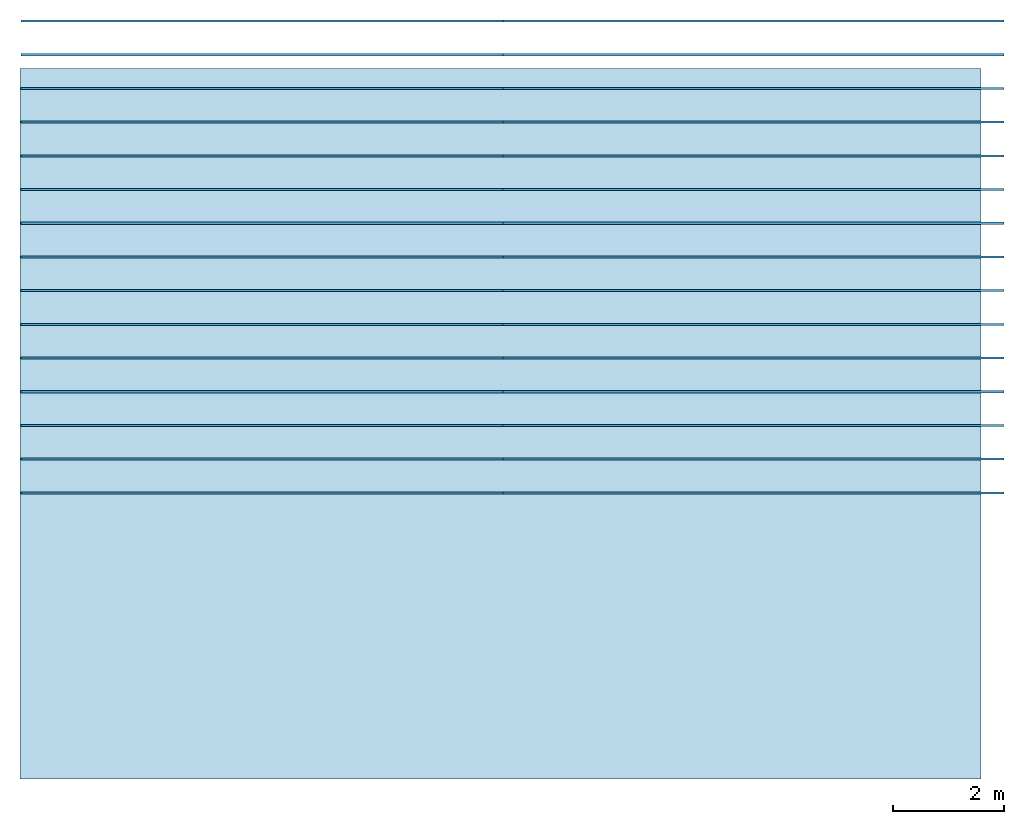
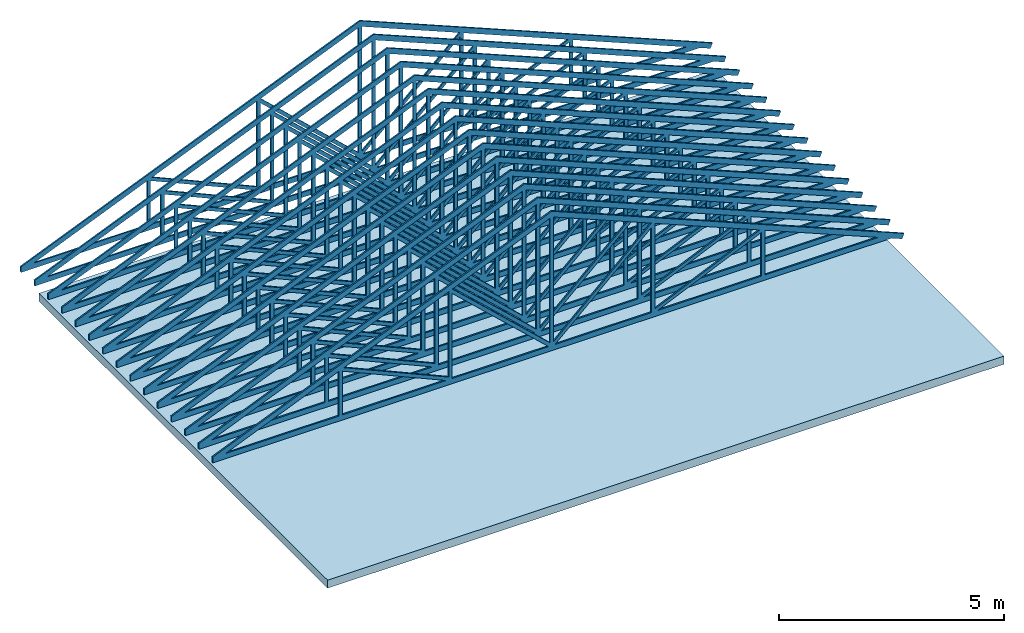
# Not in any storey: 15 assemblies, 1 slab.
"""IFC4 model written with IfcOpenShell, lengths in feet."""

from ifc_helpers import new_model, entity, si_unit, converted_unit, frame, origin_with_axes, origin_2d_with_axis, place, context, subcontext, project, line, indexed_curve, outline, extrude, polygons, source, transform, mapped, material, layer, layer_set, layer_usage, type_object, type_shapes, element, save


model = new_model("IFC4")

# Units and contexts
model_context = context("Model", 3, precision=1e-05, world=origin_with_axes())
plan_context = context("Plan", 2, precision=1e-05, world=origin_2d_with_axis())
context_of_model_1 = context(None, 3, precision=1e-05, world=origin_with_axes())
context_of_model_2 = context(None, 3, precision=1e-05, world=origin_with_axes())
body_context = subcontext(model_context, "Body", "Model", "MODEL_VIEW")
ifc_project = project(units=[converted_unit("PLANEANGLEUNIT", "degree", entity("IfcReal", 0.0174532925199433), si_unit("PLANEANGLEUNIT", "RADIAN"), dimensions=[0, 0, 0, 0, 0, 0, 0]), converted_unit("AREAUNIT", "square foot", entity("IfcReal", 0.09290304), si_unit("AREAUNIT", "SQUARE_METRE"), dimensions=[2, 0, 0, 0, 0, 0, 0]), converted_unit("LENGTHUNIT", "foot", entity("IfcReal", 0.3048), si_unit("LENGTHUNIT", "METRE"), dimensions=[1, 0, 0, 0, 0, 0, 0]), converted_unit("VOLUMEUNIT", "cubic foot", entity("IfcReal", 0.0283168467116885), si_unit("VOLUMEUNIT", "CUBIC_METRE"), dimensions=[3, 0, 0, 0, 0, 0, 0])], contexts=[model_context, plan_context, context_of_model_1, context_of_model_2])

# Slab
ifc_material_1 = material(Name="EXISTING SHEATHING")
ifc_layer_1 = layer(ifc_material_1, 0.0625)
ifc_material_2 = material(Name="EXISTING 2X8")
ifc_layer_2 = layer(ifc_material_2, 0.604166686534882, Name="Floor_LayerName")
ifc_material_3 = material()
ifc_layer_3 = layer(ifc_material_3, 0.0520833320915699)
ifc_layer_set = layer_set([ifc_layer_1, ifc_layer_2, ifc_layer_3])
ifc_layer_usage = layer_usage(ifc_layer_set, "AXIS3", "POSITIVE", 0.0)
slab_type = type_object("IfcSlabType", Name="CEILING W", PredefinedType="NOTDEFINED", material=ifc_layer_set)
slab_placement = place(None, frame((-264.634285073268, 20.1451387305272, 8.14583357863539), z_axis=(0.0, 0.0, 1.0), x_axis=(1.0, 0.0, 0.0)))
element("IfcSlab", 1, at=slab_placement, type_object=slab_type, material=ifc_layer_usage, Name="Slab", context=body_context, shape_type="SweptSolid", body=[
    extrude(outline(indexed_curve([(-32.96641852912, 14.4209871141929), (-32.96641852912, -27.7555426900468), (24.0749449241818, -27.7555426900468), (24.0749449241818, 14.4209871141929)], segments=[line(4, 1), line(1, 2), line(2, 3), line(3, 4)], self_intersect=False)), None, (0.0, 0.0, 1.0), 0.718750018626451),
])

# Assemblies
element_assembly_type = type_object("IfcElementAssemblyType", Name="Cube", PredefinedType="TRUSS")
shared_shape = source(origin_with_axes(), body_context, "Body", "Tessellation", [
    polygons([(-57.0040626525879, 9.77766489995702e-08, -2.93329946998711e-07), (-57.0040626525879, 9.77766489995702e-08, 0.458332926034927), (-57.0040626525879, 0.124999918043613, -2.93329946998711e-07), (-57.0040626525879, 0.124999918043613, 0.458332926034927), (0.18902650475502, 9.77766489995702e-08, -2.93329946998711e-07), (0.18902650475502, 9.77766489995702e-08, 0.458332926034927), (0.18902650475502, 0.124999918043613, -2.93329946998711e-07), (0.18902650475502, 0.124999918043613, 0.458332926034927), (-28.5886039733887, 7.82213191996561e-07, 12.0082445144653), (-28.412317276001, 7.82213191996561e-07, 12.431321144104), (-28.5886039733887, 0.125000596046448, 12.0082445144653), (-28.412317276001, 0.125000596046448, 12.431321144104), (1.13409721851349, 7.82213191996561e-07, -0.376156091690063), (1.31038308143616, 7.82213191996561e-07, 0.0469195432960987), (1.13409721851349, 0.125000596046448, -0.376156091690063), (1.31038308143616, 0.125000596046448, 0.0469195432960987), (-10.7424001693726, 2.93329946998711e-07, 4.64991426467896), (-10.4507331848145, 2.93329946998711e-07, 4.64991426467896), (-10.7424001693726, 0.12500011920929, 4.64991426467896), (-10.4507331848145, 0.12500011920929, 4.64991426467896), (-10.7424030303955, 2.93329946998711e-07, 0.458333134651184), (-10.4507331848145, 2.93329946998711e-07, 0.458333134651184), (-10.7424030303955, 0.12500011920929, 0.458333134651184), (-10.4507331848145, 0.12500011920929, 0.458333134651184), (-10.7077054977417, 1.56442638399312e-06, 4.69126462936401), (-10.5890731811523, 1.56442638399312e-06, 4.42481327056885), (-10.7077054977417, 0.125001579523087, 4.69126462936401), (-10.5890731811523, 0.125001579523087, 4.42481327056885), (-19.853630065918, 1.56442638399312e-06, 0.61924535036087), (-19.7349987030029, 1.56442638399312e-06, 0.352791458368301), (-19.853630065918, 0.125001579523087, 0.61924535036087), (-19.7349987030029, 0.125001579523087, 0.352791458368301), (-20.0038547515869, 2.93329946998711e-07, 8.36087226867676), (-19.7121868133545, 2.93329946998711e-07, 8.36087226867676), (-20.0038547515869, 0.12500011920929, 8.36087226867676), (-19.7121868133545, 0.12500011920929, 8.36087226867676), (-20.0038566589355, 2.93329946998711e-07, 0.458333134651184), (-19.7121868133545, 2.93329946998711e-07, 0.458333134651184), (-20.0038566589355, 0.12500011920929, 0.458333134651184), (-19.7121868133545, 0.12500011920929, 0.458333134651184), (-19.8458728790283, -2.63667629951669e-08, 8.58856296539307), (-19.6469573974609, -2.63667629951669e-08, 8.37525081634521), (-19.8458728790283, 0.125000774860382, 8.58856296539307), (-19.6469573974609, 0.125000774860382, 8.37525081634521), (-28.5895881652832, -2.63667629951669e-08, 0.434924334287643), (-28.3906726837158, -2.63667629951669e-08, 0.221609696745872), (-28.5895881652832, 0.125000774860382, 0.434924334287643), (-28.3906726837158, 0.125000774860382, 0.221609696745872), (-28.5533561706543, 2.93329946998711e-07, 11.9680738449097), (-28.2616882324219, 2.93329946998711e-07, 11.9680738449097), (-28.5533561706543, 0.12500011920929, 11.9680738449097), (-28.2616882324219, 0.12500011920929, 11.9680738449097), (-28.5533599853516, 2.93329946998711e-07, 0.458333134651184), (-28.2616882324219, 2.93329946998711e-07, 0.458333134651184), (-28.5533599853516, 0.12500011920929, 0.458333134651184), (-28.2616882324219, 0.12500011920929, 0.458333134651184), (-28.2312564849854, 0.0, 12.006236076355), (-28.407543182373, 0.0, 12.429313659668), (-28.2312564849854, 0.125000789761543, 12.006236076355), (-28.407543182373, 0.125000789761543, 12.429313659668), (-56.8476181030273, 0.0, 0.0828209072351456), (-57.0239067077637, 0.0, 0.505896508693695), (-56.8476181030273, 0.125000789761543, 0.0828209072351456), (-57.0239067077637, 0.125000789761543, 0.505896508693695), (-46.0726623535156, 2.93329946998711e-07, 4.64991426467896), (-46.364330291748, 2.93329946998711e-07, 4.64991426467896), (-46.0726623535156, 0.12500011920929, 4.64991426467896), (-46.364330291748, 0.12500011920929, 4.64991426467896), (-46.0726585388184, 2.93329946998711e-07, 0.458333134651184), (-46.364330291748, 2.93329946998711e-07, 0.458333134651184), (-46.0726585388184, 0.12500011920929, 0.458333134651184), (-46.364330291748, 0.12500011920929, 0.458333134651184), (-46.1073570251465, 1.56442638399312e-06, 4.69126510620117), (-46.2259864807129, 1.56442638399312e-06, 4.42481327056885), (-46.1073570251465, 0.125001579523087, 4.69126510620117), (-46.2259864807129, 0.125001579523087, 4.42481327056885), (-36.9614334106445, 1.56442638399312e-06, 0.61924535036087), (-37.0800628662109, 1.56442638399312e-06, 0.352791458368301), (-36.9614334106445, 0.125001579523087, 0.61924535036087), (-37.0800628662109, 0.125001579523087, 0.352791458368301), (-36.811206817627, 2.93329946998711e-07, 8.36087226867676), (-37.1028747558594, 2.93329946998711e-07, 8.36087226867676), (-36.811206817627, 0.12500011920929, 8.36087226867676), (-37.1028747558594, 0.12500011920929, 8.36087226867676), (-36.8112030029297, 2.93329946998711e-07, 0.458333134651184), (-37.1028747558594, 2.93329946998711e-07, 0.458333134651184), (-36.8112030029297, 0.12500011920929, 0.458333134651184), (-37.1028747558594, 0.12500011920929, 0.458333134651184), (-36.9691848754883, -2.44441622498925e-08, 8.58856296539307), (-37.1681022644043, -2.44441622498925e-08, 8.37525081634521), (-36.9691848754883, 0.125000774860382, 8.58856296539307), (-37.1681022644043, 0.125000774860382, 8.37525081634521), (-28.225471496582, -2.44441622498925e-08, 0.434924602508545), (-28.424388885498, -2.44441622498925e-08, 0.221609607338905), (-28.225471496582, 0.125000774860382, 0.434924602508545), (-28.424388885498, 0.125000774860382, 0.221609607338905)], [[[2, 3, 1]], [[3, 4, 8, 7]], [[7, 8, 6, 5]], [[5, 6, 2, 1]], [[3, 7, 5, 1]], [[8, 4, 2, 6]], [[9, 10, 12, 11]], [[11, 12, 16, 15]], [[15, 16, 14, 13]], [[13, 14, 10, 9]], [[11, 15, 13, 9]], [[16, 12, 10, 14]], [[17, 18, 20, 19]], [[19, 20, 24, 23]], [[23, 24, 22, 21]], [[21, 22, 18, 17]], [[19, 23, 21, 17]], [[24, 20, 18, 22]], [[25, 26, 28, 27]], [[27, 28, 32, 31]], [[31, 32, 30, 29]], [[29, 30, 26, 25]], [[27, 31, 29, 25]], [[32, 28, 26, 30]], [[33, 34, 36, 35]], [[35, 36, 40, 39]], [[39, 40, 38, 37]], [[37, 38, 34, 33]], [[35, 39, 37, 33]], [[40, 36, 34, 38]], [[41, 42, 44, 43]], [[43, 44, 48, 47]], [[47, 48, 46, 45]], [[45, 46, 42, 41]], [[43, 47, 45, 41]], [[48, 44, 42, 46]], [[49, 50, 52, 51]], [[51, 52, 56, 55]], [[55, 56, 54, 53]], [[53, 54, 50, 49]], [[51, 55, 53, 49]], [[56, 52, 50, 54]], [[57, 58, 60, 59]], [[59, 60, 64, 63]], [[64, 61, 63]], [[61, 62, 58, 57]], [[59, 63, 61, 57]], [[64, 60, 58, 62]], [[65, 66, 68, 67]], [[67, 68, 72, 71]], [[71, 72, 70, 69]], [[69, 70, 66, 65]], [[67, 71, 69, 65]], [[72, 68, 66, 70]], [[74, 75, 73]], [[75, 76, 80, 79]], [[79, 80, 78, 77]], [[77, 78, 74, 73]], [[75, 79, 77, 73]], [[80, 76, 74, 78]], [[81, 82, 84, 83]], [[83, 84, 88, 87]], [[87, 88, 86, 85]], [[85, 86, 82, 81]], [[83, 87, 85, 81]], [[88, 84, 82, 86]], [[89, 90, 92, 91]], [[91, 92, 96, 95]], [[95, 96, 94, 93]], [[93, 94, 90, 89]], [[91, 95, 93, 89]], [[96, 92, 90, 94]], [[2, 4, 3]], [[64, 62, 61]], [[74, 76, 75]]], closed=True),
])
type_shapes(element_assembly_type, [shared_shape])
for number, where, z_axis, x_axis, name in (
    (2, (-240.508452488056, 37.3206489042347, 9.01210574027434), (0.0, 0.0, 1.0), (1.0, 0.0, 0.0), "ElementAssembly"),
    (3, (-240.508452488056, 35.3206486839635, 9.01210574027434), (0.0, 0.0, 1.0), (1.0, 0.0, 0.0), "ElementAssembly"),
    (4, (-240.508452488056, 33.3206484636923, 9.01210574027434), (0.0, 0.0, 1.0), (1.0, 0.0, 0.0), "ElementAssembly"),
    (5, (-240.508452488056, 31.320648243421, 9.01210574027434), (0.0, 0.0, 1.0), (1.0, 0.0, 0.0), "ElementAssembly"),
    (6, (-240.508452488056, 29.3206480231498, 9.01210574027434), (0.0, 0.0, 1.0), (1.0, 0.0, 0.0), "ElementAssembly"),
    (7, (-240.508452488056, 27.3206478028786, 9.01210574027434), (0.0, 0.0, 1.0), (1.0, 0.0, 0.0), "ElementAssembly"),
    (8, (-240.508452488056, 25.3206491470337, 9.01210574027434), (0.0, 0.0, 1.0), (1.0, 0.0, 0.0), "ElementAssembly"),
    (9, (-240.508452488056, 23.3206489267625, 9.01210574027434), (0.0, 0.0, 1.0), (1.0, 0.0, 0.0), "ElementAssembly"),
    (10, (-240.508452488056, 21.3206487064912, 9.01210574027434), (0.0, 0.0, 1.0), (1.0, 0.0, 0.0), "ElementAssembly"),
    (11, (-240.508452488056, 19.32064848622, 9.01210574027434), (0.0, 0.0, 1.0), (1.0, 0.0, 0.0), "ElementAssembly"),
    (12, (-240.508452488056, 17.3206482659488, 9.01210574027434), (0.0, 0.0, 1.0), (1.0, 0.0, 0.0), "ElementAssembly"),
    (13, (-240.508452488056, 15.3206480456775, 9.01210574027434), (0.0, 0.0, 1.0), (1.0, 0.0, 0.0), "ElementAssembly"),
    (14, (-240.508452488056, 13.3206493898327, 9.01210574027434), (0.0, 0.0, 1.0), (1.0, 0.0, 0.0), "ElementAssembly"),
    (15, (-240.508452488056, 11.3206491695614, 9.01210574027434), (0.0, 0.0, 1.0), (1.0, 0.0, 0.0), "ElementAssembly"),
    (16, (-240.508452488056, 9.3206489492902, 9.01210574027434), (0.0, 0.0, 1.0), (1.0, 0.0, 0.0), "ElementAssembly"),
):
    element("IfcElementAssembly", number, at=place(None, frame(where, z_axis=z_axis, x_axis=x_axis)), type_object=element_assembly_type, Name=name, context=body_context, shape_type="MappedRepresentation", body=[
        mapped(shared_shape, transform((0.0, 0.0, 0.0), x_axis=(1.0, 0.0, 0.0), y_axis=(0.0, 1.0, 0.0), z_axis=(0.0, 0.0, 1.0), scale=1.0)),
    ])

save(model, "model.ifc")
